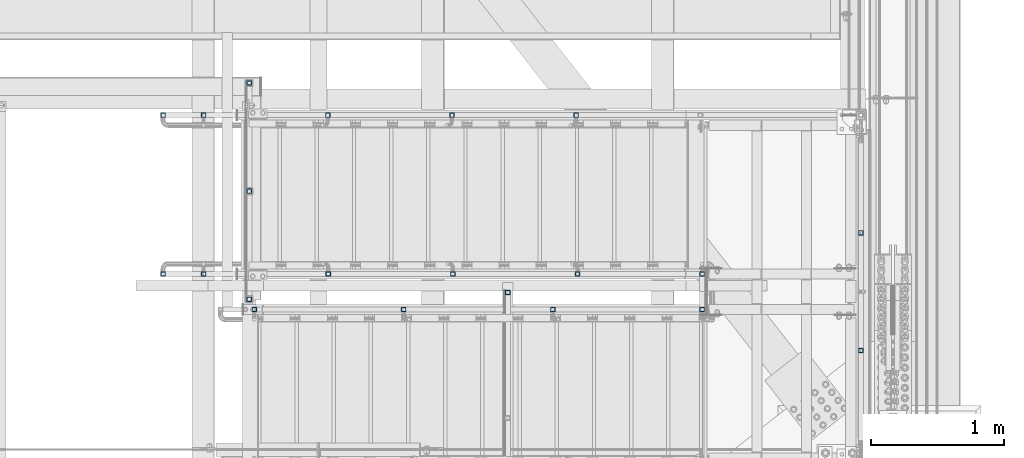
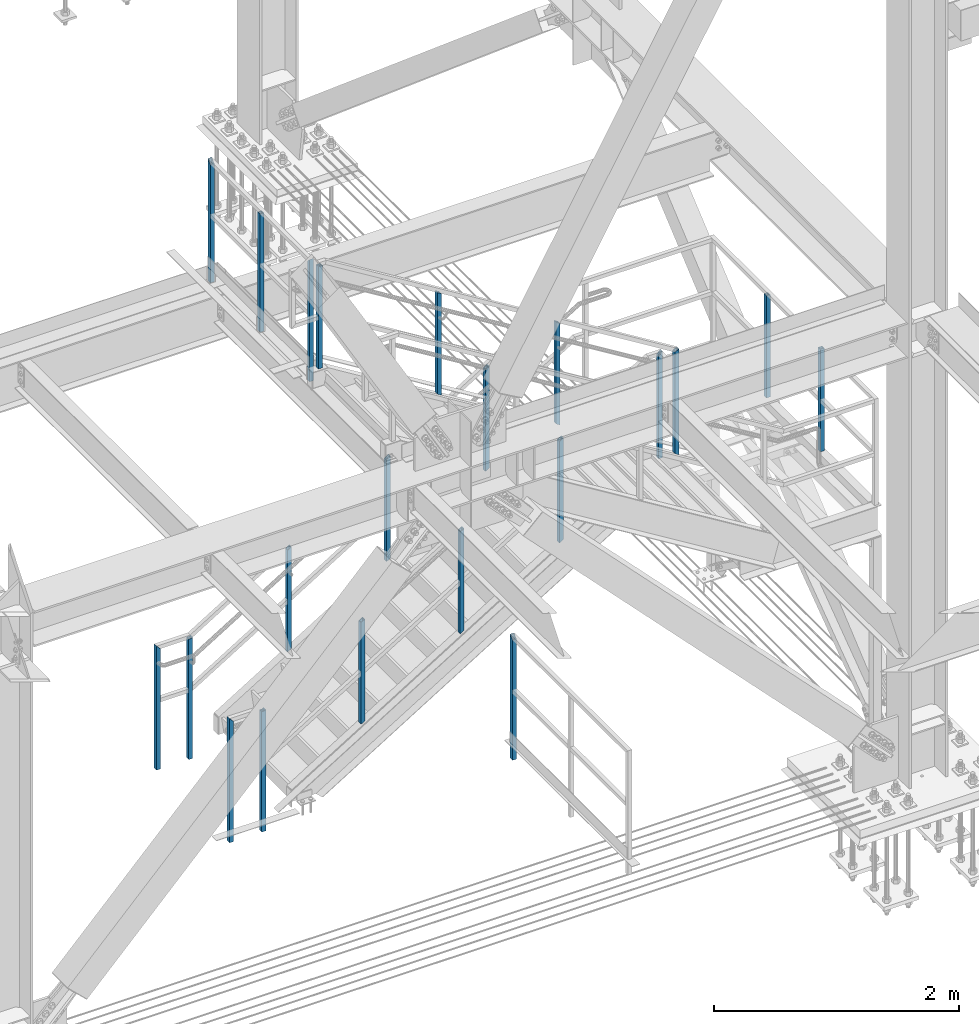
# One storey, part 1411 of 3843: 21 columns, 6 elements without a shape of their own.
"""IFC2X3 building model written with IfcOpenShell, lengths in millimetres."""

from ifc_helpers import new_model, si_unit, frame, origin_with_axes, place, context, subcontext, project, spatial, faceted_brep, material, type_object, element, aggregate, save


model = new_model("IFC2X3")

# Units and contexts
model_context = context("Model", 3, precision=1e-05, world=origin_with_axes())
body_context = subcontext(model_context, "Body", "Model", "MODEL_VIEW")
ifc_project = project(units=[si_unit("LENGTHUNIT", "METRE", prefix="MILLI"), si_unit("AREAUNIT", "SQUARE_METRE"), si_unit("VOLUMEUNIT", "CUBIC_METRE"), si_unit("MASSUNIT", "GRAM", prefix="KILO"), si_unit("TIMEUNIT", "SECOND"), si_unit("PLANEANGLEUNIT", "RADIAN"), si_unit("SOLIDANGLEUNIT", "STERADIAN"), si_unit("THERMODYNAMICTEMPERATUREUNIT", "DEGREE_CELSIUS"), si_unit("LUMINOUSINTENSITYUNIT", "LUMEN")], contexts=[model_context])

# Site, building, storey
site_placement = place(None, origin_with_axes())
site = spatial("IfcSite", under=ifc_project, at=site_placement, CompositionType="ELEMENT")
building_placement = place(site_placement, origin_with_axes())
building = spatial("IfcBuilding", under=site, at=building_placement, Name="Undefined", CompositionType="ELEMENT")
storey_placement = place(building_placement, origin_with_axes())
storey = spatial("IfcBuildingStorey", under=building, at=storey_placement, Name="Undefined", CompositionType="ELEMENT", Elevation=0.0)

# Assembly, column
assembly_1_placement = place(storey_placement, origin_with_axes())
assembly_1 = element("IfcElementAssembly", 1, at=assembly_1_placement, inside=storey, Name="RAIL", AssemblyPlace="NOTDEFINED", PredefinedType="RIGID_FRAME")
ifc_material = material()
column_type = type_object("IfcColumnType", Name="HSS1-1/2X1-1/2X1/4", PredefinedType="NOTDEFINED")
column_1_placement = place(assembly_1_placement, frame((84213.6999999997, 16725.9, 32715.1999999846), z_axis=(-1.0, 0.0, 0.0), x_axis=(0.0, 0.0, 1.0)))
column_1 = element("IfcColumn", 2, at=column_1_placement, type_object=column_type, material=ifc_material, Name="POST", ObjectType="HSS1-1/2X1-1/2X1/4", context=body_context, shape_type="Brep", body=[
    faceted_brep([(1047.75000076629, -19.0499992350015, 19.0499992349942), (1047.75000076629, 19.0499992350015, 19.0499992349942), (25.4000000135893, 19.0499992350015, 19.0499992349942), (25.4000000135893, -19.0499992350015, 19.0499992349942), (1085.84999923629, -19.0499992350015, -19.0499992349942), (25.4000000135893, -19.0499992350015, -19.0499992349942), (1085.84999923629, 19.0499992350015, -19.0499992349942), (25.4000000135893, 19.0499992350015, -19.0499992349942), (1054.10000067129, -12.6999993300014, 12.6999993299978), (1054.10000067129, 12.6999993300014, 12.6999993299978), (1079.49999933128, 12.6999993300014, -12.6999993299978), (1079.49999933128, -12.6999993300014, -12.6999993299978), (25.4000000135893, -12.6999993300014, 12.6999993299978), (25.4000000135893, 12.6999993300014, 12.6999993299978), (25.4000000135893, 12.6999993300014, -12.6999993299978), (25.4000000135893, -12.6999993300014, -12.6999993299978)], [[[0, 1, 2, 3]], [[4, 0, 3, 5]], [[6, 4, 5, 7]], [[1, 6, 7, 2]], [[0, 4, 6, 1], [8, 9, 10, 11]], [[9, 8, 12, 13]], [[10, 9, 13, 14]], [[11, 10, 14, 15]], [[8, 11, 15, 12]], [[7, 5, 3, 2], [14, 13, 12, 15]]]),
])

# Assembly, columns
assembly_2_placement = place(storey_placement, origin_with_axes())
assembly_2 = element("IfcElementAssembly", 3, at=assembly_2_placement, inside=storey, Name="RAIL", AssemblyPlace="NOTDEFINED", PredefinedType="RIGID_FRAME")
column_2_placement = place(assembly_2_placement, frame((80810.1, 17348.2, 34950.4), z_axis=(-1.0, 0.0, 0.0), x_axis=(0.0, 0.0, 1.0)))
column_2 = element("IfcColumn", 4, at=column_2_placement, type_object=column_type, material=ifc_material, Name="POST", ObjectType="HSS1-1/2X1-1/2X1/4", context=body_context, shape_type="Brep", body=[
    faceted_brep([(-133.350000731458, 12.6999993300014, -12.6999993299978), (-133.350000731458, -12.6999993300014, -12.6999993299978), (1047.75000076497, -12.6999993300014, -12.6999993299978), (1047.75000076497, 12.6999993300014, -12.6999993299978), (-133.350000731458, -12.6999993300014, 12.6999993299978), (1047.75000076497, -12.6999993300014, 12.6999993299978), (-133.350000731458, 12.6999993300014, 12.6999993299978), (1047.75000076497, 12.6999993300014, 12.6999993299978), (-133.350000731458, 19.0499992350015, -19.0499992350015), (-133.350000731458, 19.0499992350015, 19.0499992350015), (1047.75000076629, 19.0499992350015, 19.0499992349942), (1047.750000765, 19.0499992350015, -19.0499992350015), (-133.350000731458, -19.0499992350015, 19.0499992350015), (1047.75000076629, -19.0499992350015, 19.0499992349942), (-133.350000731458, -19.0499992350015, -19.0499992350015), (1047.750000765, -19.0499992350015, -19.0499992350015)], [[[0, 1, 2, 3]], [[1, 4, 5, 2]], [[4, 6, 7, 5]], [[6, 0, 3, 7]], [[8, 9, 10, 11]], [[9, 12, 13, 10]], [[12, 14, 15, 13]], [[14, 8, 11, 15]], [[13, 15, 11, 10], [5, 7, 3, 2]], [[14, 12, 9, 8], [6, 4, 1, 0]]]),
])
column_3_placement = place(assembly_2_placement, frame((80810.1, 16535.4, 34950.4), z_axis=(-1.0, 0.0, 0.0), x_axis=(0.0, 0.0, 1.0)))
column_3 = element("IfcColumn", 5, at=column_3_placement, type_object=column_type, material=ifc_material, Name="POST", ObjectType="HSS1-1/2X1-1/2X1/4", context=body_context, shape_type="Brep", body=[
    faceted_brep([(-133.350000731458, 12.6999993300014, -12.6999993299978), (-133.350000731458, -12.6999993300014, -12.6999993299978), (1079.49999933128, -12.6999993300014, -12.6999993299978), (1054.10000067001, 12.6999993300014, -12.6999993299978), (-133.350000731458, -12.6999993300014, 12.6999993299978), (1079.49999933, -12.6999993300014, 12.6999993299978), (-133.350000731458, 12.6999993300014, 12.6999993299978), (1054.10000067129, 12.6999993300014, 12.6999993299978), (-133.350000731458, 19.0499992350015, -19.0499992350015), (-133.350000731458, 19.0499992350015, 19.0499992350015), (1047.75000076629, 19.0499992350015, 19.0499992349942), (1047.750000765, 19.0499992350015, -19.0499992350015), (-133.350000731458, -19.0499992350015, 19.0499992350015), (1085.849999235, -19.0499992350015, 19.0499992350015), (-133.350000731458, -19.0499992350015, -19.0499992350015), (1085.84999923629, -19.0499992350015, -19.0499992349942)], [[[0, 1, 2, 3]], [[1, 4, 5, 2]], [[4, 6, 7, 5]], [[6, 0, 3, 7]], [[8, 9, 10, 11]], [[9, 12, 13, 10]], [[12, 14, 15, 13]], [[14, 8, 11, 15]], [[13, 15, 11, 10], [5, 7, 3, 2]], [[14, 12, 9, 8], [6, 4, 1, 0]]]),
])
column_4_placement = place(assembly_2_placement, frame((80810.1, 18161.0, 34950.4), z_axis=(-1.0, 0.0, 0.0), x_axis=(0.0, 0.0, 1.0)))
column_4 = element("IfcColumn", 6, at=column_4_placement, type_object=column_type, material=ifc_material, Name="POST", ObjectType="HSS1-1/2X1-1/2X1/4", context=body_context, shape_type="Brep", body=[
    faceted_brep([(-133.350000731458, 12.6999993300014, -12.6999993299978), (-133.350000731458, -12.6999993300014, -12.6999993299978), (1054.10000067001, -12.6999993300014, -12.6999993299978), (1079.49999933128, 12.6999993300014, -12.6999993299978), (-133.350000731458, -12.6999993300014, 12.6999993299978), (1054.10000067129, -12.6999993300014, 12.6999993299978), (-133.350000731458, 12.6999993300014, 12.6999993299978), (1079.49999933, 12.6999993300014, 12.6999993299978), (-133.350000731458, 19.0499992350015, -19.0499992350015), (-133.350000731458, 19.0499992350015, 19.0499992350015), (1085.849999235, 19.0499992350015, 19.0499992350015), (1085.84999923629, 19.0499992350015, -19.0499992349942), (-133.350000731458, -19.0499992350015, 19.0499992350015), (1047.75000076629, -19.0499992350015, 19.0499992349942), (-133.350000731458, -19.0499992350015, -19.0499992350015), (1047.750000765, -19.0499992350015, -19.0499992350015)], [[[0, 1, 2, 3]], [[1, 4, 5, 2]], [[4, 6, 7, 5]], [[6, 0, 3, 7]], [[8, 9, 10, 11]], [[9, 12, 13, 10]], [[12, 14, 15, 13]], [[14, 8, 11, 15]], [[13, 15, 11, 10], [5, 7, 3, 2]], [[14, 12, 9, 8], [6, 4, 1, 0]]]),
])
aggregate(assembly_2, [column_2, column_3, column_4])

# Assembly, column
assembly_3_placement = place(storey_placement, origin_with_axes())
assembly_3 = element("IfcElementAssembly", 7, at=assembly_3_placement, inside=storey, Name="RAIL", AssemblyPlace="NOTDEFINED", PredefinedType="RIGID_FRAME")
column_5_placement = place(assembly_3_placement, frame((82753.1999999997, 16586.2, 30480.0), z_axis=(-1.0, 0.0, 0.0), x_axis=(0.0, 0.0, 1.0)))
column_5 = element("IfcColumn", 8, at=column_5_placement, type_object=column_type, material=ifc_material, Name="POST", ObjectType="HSS1-1/2X1-1/2X1/4", context=body_context, shape_type="Brep", body=[
    faceted_brep([(-152.399999977541, 12.6999993299978, -12.6999993299978), (-152.399999977541, -12.6999993299978, -12.6999993299978), (1054.10000067001, -12.6999993300014, -12.6999993299978), (1079.49999933128, 12.6999993300014, -12.6999993299978), (-152.399999977541, -12.6999993299978, 12.6999993299978), (1054.10000067129, -12.6999993300014, 12.6999993299978), (-152.399999977541, 12.6999993299978, 12.6999993299978), (1079.49999933, 12.6999993300014, 12.6999993299978), (-152.399999977541, 19.0499992350015, -19.0499992349942), (-152.399999977541, 19.0499992350015, 19.0499992349942), (1085.849999235, 19.0499992350015, 19.0499992350015), (1085.84999923629, 19.0499992350015, -19.0499992349942), (-152.399999977541, -19.0499992350015, 19.0499992349942), (1047.75000076629, -19.0499992350015, 19.0499992349942), (-152.399999977541, -19.0499992350015, -19.0499992349942), (1047.750000765, -19.0499992350015, -19.0499992350015)], [[[0, 1, 2, 3]], [[1, 4, 5, 2]], [[4, 6, 7, 5]], [[6, 0, 3, 7]], [[8, 9, 10, 11]], [[9, 12, 13, 10]], [[12, 14, 15, 13]], [[14, 8, 11, 15]], [[13, 15, 11, 10], [5, 7, 3, 2]], [[14, 12, 9, 8], [6, 4, 1, 0]]]),
])
aggregate(assembly_3, [column_5])

assembly_4_placement = place(storey_placement, origin_with_axes())
assembly_4 = element("IfcElementAssembly", 9, at=assembly_4_placement, inside=storey, Name="RAIL", AssemblyPlace="NOTDEFINED", PredefinedType="RIGID_FRAME")
column_6_placement = place(assembly_4_placement, frame((80848.2000000002, 16459.2, 34950.4), z_axis=(1.0, 0.0, 0.0), x_axis=(0.0, 0.0, 1.0)))
column_6 = element("IfcColumn", 10, at=column_6_placement, type_object=column_type, material=ifc_material, Name="POST", ObjectType="HSS1-1/2X1-1/2X1/4", context=body_context, shape_type="Brep", body=[
    faceted_brep([(1047.75000076629, -19.0499992350015, 19.0499992349942), (1047.75000076629, 19.0499992350015, 19.0499992349942), (25.4000000135893, 19.0499992350015, 19.0499992349942), (25.4000000135893, -19.0499992350015, 19.0499992349942), (1047.750000765, -19.0499992350015, -19.0499992350015), (25.4000000135893, -19.0499992350015, -19.0499992349942), (1047.750000765, 19.0499992350015, -19.0499992350015), (25.4000000135893, 19.0499992350015, -19.0499992349942), (1047.75000076497, -12.6999993300014, 12.6999993299978), (1047.75000076497, 12.6999993300014, 12.6999993299978), (1047.75000076497, 12.6999993300014, -12.6999993299978), (1047.75000076497, -12.6999993300014, -12.6999993299978), (25.4000000135893, -12.6999993300014, 12.6999993299978), (25.4000000135893, 12.6999993300014, 12.6999993299978), (25.4000000135893, 12.6999993300014, -12.6999993299978), (25.4000000135893, -12.6999993300014, -12.6999993299978)], [[[0, 1, 2, 3]], [[4, 0, 3, 5]], [[6, 4, 5, 7]], [[1, 6, 7, 2]], [[0, 4, 6, 1], [8, 9, 10, 11]], [[9, 8, 12, 13]], [[10, 9, 13, 14]], [[11, 10, 14, 15]], [[8, 11, 15, 12]], [[7, 5, 3, 2], [14, 13, 12, 15]]]),
])

# Assembly, columns
assembly_5_placement = place(storey_placement, origin_with_axes())
assembly_5 = element("IfcElementAssembly", 11, at=assembly_5_placement, inside=storey, Name="RAIL", AssemblyPlace="NOTDEFINED", PredefinedType="RIGID_FRAME")
column_7_placement = place(assembly_5_placement, frame((83267.5499999997, 17919.7, 32233.1164747212), z_axis=(-1.0, 0.0, 0.0), x_axis=(0.0, 0.0, 1.0)))
column_7 = element("IfcColumn", 12, at=column_7_placement, type_object=column_type, material=ifc_material, Name="POST", ObjectType="HSS1-1/2X1-1/2X1/4", context=body_context, shape_type="Brep", body=[
    faceted_brep([(7.81538423420716, 12.6999993299978, -12.6999993300014), (7.81538423420716, -12.6999993299978, -12.6999993300014), (1022.42309164321, -12.6999993299978, -12.6999993300014), (1022.42309164321, 12.6999993299978, -12.6999993300014), (-7.81538414671377, -12.6999993299978, 12.6999993300014), (1006.79232326229, -12.6999993299978, 12.6999993300014), (-7.81538414671377, 12.6999993299978, 12.6999993300014), (1006.79232326229, 12.6999993299978, 12.6999993300014), (11.7230764771302, 19.0499992350015, -19.0499992350015), (-11.7230763896368, 19.0499992350015, 19.0499992350015), (1002.88463101937, 19.0499992350015, 19.0499992350015), (1026.33078388613, 19.0499992350015, -19.0499992350015), (-11.7230763896368, -19.0499992350015, 19.0499992350015), (1002.88463101937, -19.0499992350015, 19.0499992350015), (11.7230764771302, -19.0499992350015, -19.0499992350015), (1026.33078388613, -19.0499992350015, -19.0499992350015)], [[[0, 1, 2, 3]], [[1, 4, 5, 2]], [[4, 6, 7, 5]], [[6, 0, 3, 7]], [[8, 9, 10, 11]], [[9, 12, 13, 10]], [[12, 14, 15, 13]], [[14, 8, 11, 15]], [[13, 15, 11, 10], [5, 7, 3, 2]], [[14, 12, 9, 8], [6, 4, 1, 0]]]),
])
column_8_placement = place(assembly_5_placement, frame((82334.0999999997, 17919.7, 31658.6857053218), z_axis=(-1.0, 0.0, 0.0), x_axis=(0.0, 0.0, 1.0)))
column_8 = element("IfcColumn", 13, at=column_8_placement, type_object=column_type, material=ifc_material, Name="POST", ObjectType="HSS1-1/2X1-1/2X1/4", context=body_context, shape_type="Brep", body=[
    faceted_brep([(7.81538423420716, 12.6999993299978, -12.6999993300014), (7.81538423420716, -12.6999993299978, -12.6999993300014), (1022.42309164321, -12.6999993299978, -12.6999993300014), (1022.42309164321, 12.6999993299978, -12.6999993300014), (-7.81538414671377, -12.6999993299978, 12.6999993300014), (1006.79232326229, -12.6999993299978, 12.6999993300014), (-7.81538414671377, 12.6999993299978, 12.6999993300014), (1006.79232326229, 12.6999993299978, 12.6999993300014), (11.7230764771302, 19.0499992350015, -19.0499992350015), (-11.7230763896368, 19.0499992350015, 19.0499992350015), (1002.88463101937, 19.0499992350015, 19.0499992350015), (1026.33078388613, 19.0499992350015, -19.0499992350015), (-11.7230763896368, -19.0499992350015, 19.0499992350015), (1002.88463101937, -19.0499992350015, 19.0499992350015), (11.7230764771302, -19.0499992350015, -19.0499992350015), (1026.33078388613, -19.0499992350015, -19.0499992350015)], [[[0, 1, 2, 3]], [[1, 4, 5, 2]], [[4, 6, 7, 5]], [[6, 0, 3, 7]], [[8, 9, 10, 11]], [[9, 12, 13, 10]], [[12, 14, 15, 13]], [[14, 8, 11, 15]], [[13, 15, 11, 10], [5, 7, 3, 2]], [[14, 12, 9, 8], [6, 4, 1, 0]]]),
])
column_9_placement = place(assembly_5_placement, frame((81400.6499999997, 17919.7, 31084.2549359224), z_axis=(-1.0, 0.0, 0.0), x_axis=(0.0, 0.0, 1.0)))
column_9 = element("IfcColumn", 14, at=column_9_placement, type_object=column_type, material=ifc_material, Name="POST", ObjectType="HSS1-1/2X1-1/2X1/4", context=body_context, shape_type="Brep", body=[
    faceted_brep([(7.81538423420716, 12.6999993299978, -12.6999993300014), (7.81538423420716, -12.6999993299978, -12.6999993300014), (1022.42309164321, -12.6999993299978, -12.6999993300014), (1022.42309164321, 12.6999993299978, -12.6999993300014), (-7.81538414671377, -12.6999993299978, 12.6999993300014), (1006.79232326229, -12.6999993299978, 12.6999993300014), (-7.81538414671377, 12.6999993299978, 12.6999993300014), (1006.79232326229, 12.6999993299978, 12.6999993300014), (11.7230764771302, 19.0499992350015, -19.0499992350015), (-11.7230763896368, 19.0499992350015, 19.0499992350015), (1002.88463101937, 19.0499992350015, 19.0499992350015), (1026.33078388613, 19.0499992350015, -19.0499992350015), (-11.7230763896368, -19.0499992350015, 19.0499992350015), (1002.88463101937, -19.0499992350015, 19.0499992350015), (11.7230764771302, -19.0499992350015, -19.0499992350015), (1026.33078388613, -19.0499992350015, -19.0499992350015)], [[[0, 1, 2, 3]], [[1, 4, 5, 2]], [[4, 6, 7, 5]], [[6, 0, 3, 7]], [[8, 9, 10, 11]], [[9, 12, 13, 10]], [[12, 14, 15, 13]], [[14, 8, 11, 15]], [[13, 15, 11, 10], [5, 7, 3, 2]], [[14, 12, 9, 8], [6, 4, 1, 0]]]),
])
column_10_placement = place(assembly_5_placement, frame((80467.1999999997, 17919.7, 30480.0), z_axis=(-1.0, 0.0, 0.0), x_axis=(0.0, 0.0, 1.0)))
column_10 = element("IfcColumn", 15, at=column_10_placement, type_object=column_type, material=ifc_material, Name="POST", ObjectType="HSS1-1/2X1-1/2X1/4", context=body_context, shape_type="Brep", body=[
    faceted_brep([(1047.75000076629, -19.0499992350015, 19.0499992349942), (1047.75000076818, -19.0499992350015, -5.39195351277885), (1047.75000076818, -12.6999993300014, -5.39195351277885), (1047.75000076497, -12.6999993300014, 12.6999993299978), (1047.75000076497, 12.6999993300014, 12.6999993299978), (1047.75000076819, 12.6999993300014, -5.39195351277885), (1047.75000076819, 19.0499992349978, -5.39195351277885), (1047.75000076629, 19.0499992350015, 19.0499992349942), (1056.15495197957, -19.0499992350051, -19.0499992350015), (1056.15495197957, 19.0499992350015, -19.0499992350015), (1052.2472597314, 12.6999993300014, -12.6999993299978), (1052.2472597314, -12.6999993300014, -12.6999993299978), (-152.399999977541, 19.0499992350015, 19.0499992349942), (-152.399999977541, -19.0499992350015, 19.0499992349942), (-152.399999977541, -19.0499992350015, -19.0499992349942), (-152.399999977541, 19.0499992350015, -19.0499992349942), (-152.399999977541, 12.6999993299978, 12.6999993299978), (-152.399999977541, -12.6999993299978, 12.6999993299978), (-152.399999977541, -12.6999993299978, -12.6999993299978), (-152.399999977541, 12.6999993299978, -12.6999993299978)], [[[0, 1, 2, 3, 4, 5, 6, 7]], [[8, 9, 6, 5, 10, 11, 2, 1]], [[12, 13, 0, 7]], [[0, 13, 14, 8, 1]], [[14, 15, 9, 8]], [[15, 12, 7, 6, 9]], [[14, 13, 12, 15], [16, 17, 18, 19]], [[19, 18, 11, 10]], [[4, 16, 19, 10, 5]], [[17, 16, 4, 3]], [[18, 17, 3, 2, 11]]]),
])
column_11_placement = place(assembly_5_placement, frame((80162.3999999997, 17919.7, 30480.0), z_axis=(-1.0, 0.0, 0.0), x_axis=(0.0, 0.0, 1.0)))
column_11 = element("IfcColumn", 16, at=column_11_placement, type_object=column_type, material=ifc_material, Name="POST", ObjectType="HSS1-1/2X1-1/2X1/4", context=body_context, shape_type="Brep", body=[
    faceted_brep([(-152.399999977541, 12.6999993299978, -12.6999993299978), (-152.399999977541, -12.6999993299978, -12.6999993299978), (1054.10000067001, -12.6999993300014, -12.6999993299978), (1054.10000067001, 12.6999993300014, -12.6999993299978), (-152.399999977541, -12.6999993299978, 12.6999993299978), (1079.49999933, -12.6999993300014, 12.6999993299978), (-152.399999977541, 12.6999993299978, 12.6999993299978), (1079.49999933, 12.6999993300014, 12.6999993299978), (-152.399999977541, 19.0499992350015, -19.0499992349942), (-152.399999977541, 19.0499992350015, 19.0499992349942), (1085.849999235, 19.0499992350015, 19.0499992350015), (1047.750000765, 19.0499992350015, -19.0499992350015), (-152.399999977541, -19.0499992350015, 19.0499992349942), (1085.849999235, -19.0499992350015, 19.0499992350015), (-152.399999977541, -19.0499992350015, -19.0499992349942), (1047.750000765, -19.0499992350015, -19.0499992350015)], [[[0, 1, 2, 3]], [[1, 4, 5, 2]], [[4, 6, 7, 5]], [[6, 0, 3, 7]], [[8, 9, 10, 11]], [[9, 12, 13, 10]], [[12, 14, 15, 13]], [[14, 8, 11, 15]], [[13, 15, 11, 10], [5, 7, 3, 2]], [[14, 12, 9, 8], [6, 4, 1, 0]]]),
])
aggregate(assembly_5, [column_7, column_8, column_9, column_10, column_11])

assembly_6_placement = place(storey_placement, origin_with_axes())
assembly_6 = element("IfcElementAssembly", 17, at=assembly_6_placement, inside=storey, Name="RAIL", AssemblyPlace="NOTDEFINED", PredefinedType="RIGID_FRAME")
column_12_placement = place(assembly_6_placement, frame((85407.4999999661, 17034.9333333333, 32740.5999999989), z_axis=(-1.0, 0.0, 0.0), x_axis=(0.0, 0.0, 1.0)))
column_12 = element("IfcColumn", 18, at=column_12_placement, type_object=column_type, material=ifc_material, Name="POST", ObjectType="HSS1-1/2X1-1/2X1/4", context=body_context, shape_type="Brep", body=[
    faceted_brep([(0.0, 12.6999993299978, -12.6999993300014), (0.0, -12.6999993299978, -12.6999993300014), (1022.35000076501, -12.6999993299978, -12.6999993300014), (1022.35000076501, 12.6999993299978, -12.6999993300014), (0.0, -12.6999993299978, 12.6999993300014), (1022.35000076501, -12.6999993299978, 12.6999993300014), (0.0, 12.6999993299978, 12.6999993300014), (1022.35000076501, 12.6999993299978, 12.6999993300014), (0.0, 19.0500000000029, -19.0499999999993), (0.0, 19.0499992350015, 19.0499992350015), (1022.35000076501, 19.0499992350015, 19.0499992350015), (1022.35000076501, 19.0499992350015, -19.0499992350015), (0.0, -19.0499992350015, 19.0499992350015), (1022.35000076501, -19.0499992350015, 19.0499992350015), (0.0, -19.0499992350015, -19.0499992350015), (1022.35000076501, -19.0499992350015, -19.0499992350015)], [[[0, 1, 2, 3]], [[1, 4, 5, 2]], [[4, 6, 7, 5]], [[6, 0, 3, 7]], [[8, 9, 10, 11]], [[9, 12, 13, 10]], [[12, 14, 15, 13]], [[14, 8, 11, 15]], [[13, 15, 11, 10], [5, 7, 3, 2]], [[14, 12, 9, 8], [6, 4, 1, 0]]]),
])
column_13_placement = place(assembly_6_placement, frame((85407.4999999661, 16150.1666666667, 32740.5999999989), z_axis=(-1.0, 0.0, 0.0), x_axis=(0.0, 0.0, 1.0)))
column_13 = element("IfcColumn", 19, at=column_13_placement, type_object=column_type, material=ifc_material, Name="POST", ObjectType="HSS1-1/2X1-1/2X1/4", context=body_context, shape_type="Brep", body=[
    faceted_brep([(0.0, 12.6999993299978, -12.6999993300014), (0.0, -12.6999993299978, -12.6999993300014), (1022.35000076501, -12.6999993299978, -12.6999993300014), (1022.35000076501, 12.6999993299978, -12.6999993300014), (0.0, -12.6999993299978, 12.6999993300014), (1022.35000076501, -12.6999993299978, 12.6999993300014), (0.0, 12.6999993299978, 12.6999993300014), (1022.35000076501, 12.6999993299978, 12.6999993300014), (0.0, 19.0500000000029, -19.0499999999993), (0.0, 19.0499992350015, 19.0499992350015), (1022.35000076501, 19.0499992350015, 19.0499992350015), (1022.35000076501, 19.0499992350015, -19.0499992350015), (0.0, -19.0499992350015, 19.0499992350015), (1022.35000076501, -19.0499992350015, 19.0499992350015), (0.0, -19.0499992350015, -19.0499992350015), (1022.35000076501, -19.0499992350015, -19.0499992350015)], [[[0, 1, 2, 3]], [[1, 4, 5, 2]], [[4, 6, 7, 5]], [[6, 0, 3, 7]], [[8, 9, 10, 11]], [[9, 12, 13, 10]], [[12, 14, 15, 13]], [[14, 8, 11, 15]], [[13, 15, 11, 10], [5, 7, 3, 2]], [[14, 12, 9, 8], [6, 4, 1, 0]]]),
])
aggregate(assembly_6, [column_12, column_13])

# Column
column_14_placement = place(assembly_4_placement, frame((81970.0333333243, 16459.2, 34321.1267310448), z_axis=(1.0, 0.0, 0.0), x_axis=(0.0, 0.0, 1.0)))
column_14 = element("IfcColumn", 20, at=column_14_placement, type_object=column_type, material=ifc_material, Name="POST", ObjectType="HSS1-1/2X1-1/2X1/4", context=body_context, shape_type="Brep", body=[
    faceted_brep([(7.81538423420716, 12.6999993299978, -12.6999993300014), (7.81538423420716, -12.6999993299978, -12.6999993300014), (1022.42309164321, -12.6999993299978, -12.6999993300014), (1022.42309164321, 12.6999993299978, -12.6999993300014), (-7.81538414671377, -12.6999993299978, 12.6999993300014), (1006.79232326229, -12.6999993299978, 12.6999993300014), (-7.81538414671377, 12.6999993299978, 12.6999993300014), (1006.79232326229, 12.6999993299978, 12.6999993300014), (11.7230764771302, 19.0499992350015, -19.0499992350015), (-11.7230763896368, 19.0499992350015, 19.0499992350015), (1002.88463101937, 19.0499992350015, 19.0499992350015), (1026.33078388613, 19.0499992350015, -19.0499992350015), (-11.7230763896368, -19.0499992350015, 19.0499992350015), (1002.88463101937, -19.0499992350015, 19.0499992350015), (11.7230764771302, -19.0499992350015, -19.0499992350015), (1026.33078388613, -19.0499992350015, -19.0499992350015)], [[[0, 1, 2, 3]], [[1, 4, 5, 2]], [[4, 6, 7, 5]], [[6, 0, 3, 7]], [[8, 9, 10, 11]], [[9, 12, 13, 10]], [[12, 14, 15, 13]], [[14, 8, 11, 15]], [[13, 15, 11, 10], [5, 7, 3, 2]], [[14, 12, 9, 8], [6, 4, 1, 0]]]),
])

column_15_placement = place(assembly_4_placement, frame((83091.8666666484, 16459.2, 33630.7677564889), z_axis=(1.0, 0.0, 0.0), x_axis=(0.0, 0.0, 1.0)))
column_15 = element("IfcColumn", 21, at=column_15_placement, type_object=column_type, material=ifc_material, Name="POST", ObjectType="HSS1-1/2X1-1/2X1/4", context=body_context, shape_type="Brep", body=[
    faceted_brep([(7.81538423420716, 12.6999993299978, -12.6999993300014), (7.81538423420716, -12.6999993299978, -12.6999993300014), (1022.42309164321, -12.6999993299978, -12.6999993300014), (1022.42309164321, 12.6999993299978, -12.6999993300014), (-7.81538414671377, -12.6999993299978, 12.6999993300014), (1006.79232326229, -12.6999993299978, 12.6999993300014), (-7.81538414671377, 12.6999993299978, 12.6999993300014), (1006.79232326229, 12.6999993299978, 12.6999993300014), (11.7230764771302, 19.0499992350015, -19.0499992350015), (-11.7230763896368, 19.0499992350015, 19.0499992350015), (1002.88463101937, 19.0499992350015, 19.0499992350015), (1026.33078388613, 19.0499992350015, -19.0499992350015), (-11.7230763896368, -19.0499992350015, 19.0499992350015), (1002.88463101937, -19.0499992350015, 19.0499992350015), (11.7230764771302, -19.0499992350015, -19.0499992350015), (1026.33078388613, -19.0499992350015, -19.0499992350015)], [[[0, 1, 2, 3]], [[1, 4, 5, 2]], [[4, 6, 7, 5]], [[6, 0, 3, 7]], [[8, 9, 10, 11]], [[9, 12, 13, 10]], [[12, 14, 15, 13]], [[14, 8, 11, 15]], [[13, 15, 11, 10], [5, 7, 3, 2]], [[14, 12, 9, 8], [6, 4, 1, 0]]]),
])

column_16_placement = place(assembly_4_placement, frame((84213.6999999724, 16459.2, 32940.408781933), z_axis=(1.0, 0.0, 0.0), x_axis=(0.0, 0.0, 1.0)))
column_16 = element("IfcColumn", 22, at=column_16_placement, type_object=column_type, material=ifc_material, Name="POST", ObjectType="HSS1-1/2X1-1/2X1/4", context=body_context, shape_type="Brep", body=[
    faceted_brep([(7.81538423420716, 12.6999993299978, -12.6999993300014), (7.81538423420716, -12.6999993299978, -12.6999993300014), (1029.87913425495, -12.6999993299978, -12.6999993300014), (1029.87913425495, 12.6999993299978, -12.6999993300014), (-7.81538414671377, -12.6999993299978, 12.6999993300014), (1044.07253145806, -12.6999993299978, 12.6999993300014), (-7.81538414671377, 12.6999993299978, 12.6999993300014), (1044.07253145806, 12.6999993299978, 12.6999993300014), (11.7230764771302, 19.0499992350015, -19.0499992350015), (-11.7230763896368, 19.0499992350015, 19.0499992350015), (1047.62088089295, 19.0499992350015, 19.0499992350015), (1026.33078388613, 19.0499992350015, -19.0499992350015), (-11.7230763896368, -19.0499992350015, 19.0499992350015), (1047.62088089295, -19.0499992350015, 19.0499992350015), (11.7230764771302, -19.0499992350015, -19.0499992350015), (1026.33078388613, -19.0499992350015, -19.0499992350015)], [[[0, 1, 2, 3]], [[1, 4, 5, 2]], [[4, 6, 7, 5]], [[6, 0, 3, 7]], [[8, 9, 10, 11]], [[9, 12, 13, 10]], [[12, 14, 15, 13]], [[14, 8, 11, 15]], [[13, 15, 11, 10], [5, 7, 3, 2]], [[14, 12, 9, 8], [6, 4, 1, 0]]]),
])

aggregate(assembly_4, [column_6, column_14, column_15, column_16])

column_17_placement = place(assembly_1_placement, frame((83277.0749999997, 16725.9, 32238.9780131844), z_axis=(-1.0, 0.0, 0.0), x_axis=(0.0, 0.0, 1.0)))
column_17 = element("IfcColumn", 23, at=column_17_placement, type_object=column_type, material=ifc_material, Name="POST", ObjectType="HSS1-1/2X1-1/2X1/4", context=body_context, shape_type="Brep", body=[
    faceted_brep([(7.81538423420716, 12.6999993299978, -12.6999993300014), (7.81538423420716, -12.6999993299978, -12.6999993300014), (1022.42309164321, -12.6999993299978, -12.6999993300014), (1022.42309164321, 12.6999993299978, -12.6999993300014), (-7.81538414671377, -12.6999993299978, 12.6999993300014), (1006.79232326229, -12.6999993299978, 12.6999993300014), (-7.81538414671377, 12.6999993299978, 12.6999993300014), (1006.79232326229, 12.6999993299978, 12.6999993300014), (11.7230764771302, 19.0499992350015, -19.0499992350015), (-11.7230763896368, 19.0499992350015, 19.0499992350015), (1002.88463101937, 19.0499992350015, 19.0499992350015), (1026.33078388613, 19.0499992350015, -19.0499992350015), (-11.7230763896368, -19.0499992350015, 19.0499992350015), (1002.88463101937, -19.0499992350015, 19.0499992350015), (11.7230764771302, -19.0499992350015, -19.0499992350015), (1026.33078388613, -19.0499992350015, -19.0499992350015)], [[[0, 1, 2, 3]], [[1, 4, 5, 2]], [[4, 6, 7, 5]], [[6, 0, 3, 7]], [[8, 9, 10, 11]], [[9, 12, 13, 10]], [[12, 14, 15, 13]], [[14, 8, 11, 15]], [[13, 15, 11, 10], [5, 7, 3, 2]], [[14, 12, 9, 8], [6, 4, 1, 0]]]),
])

column_18_placement = place(assembly_1_placement, frame((82340.4499999997, 16725.9, 31662.5933976306), z_axis=(-1.0, 0.0, 0.0), x_axis=(0.0, 0.0, 1.0)))
column_18 = element("IfcColumn", 24, at=column_18_placement, type_object=column_type, material=ifc_material, Name="POST", ObjectType="HSS1-1/2X1-1/2X1/4", context=body_context, shape_type="Brep", body=[
    faceted_brep([(7.81538423420716, 12.6999993299978, -12.6999993300014), (7.81538423420716, -12.6999993299978, -12.6999993300014), (1022.42309164321, -12.6999993299978, -12.6999993300014), (1022.42309164321, 12.6999993299978, -12.6999993300014), (-7.81538414671377, -12.6999993299978, 12.6999993300014), (1006.79232326229, -12.6999993299978, 12.6999993300014), (-7.81538414671377, 12.6999993299978, 12.6999993300014), (1006.79232326229, 12.6999993299978, 12.6999993300014), (11.7230764771302, 19.0499992350015, -19.0499992350015), (-11.7230763896368, 19.0499992350015, 19.0499992350015), (1002.88463101937, 19.0499992350015, 19.0499992350015), (1026.33078388613, 19.0499992350015, -19.0499992350015), (-11.7230763896368, -19.0499992350015, 19.0499992350015), (1002.88463101937, -19.0499992350015, 19.0499992350015), (11.7230764771302, -19.0499992350015, -19.0499992350015), (1026.33078388613, -19.0499992350015, -19.0499992350015)], [[[0, 1, 2, 3]], [[1, 4, 5, 2]], [[4, 6, 7, 5]], [[6, 0, 3, 7]], [[8, 9, 10, 11]], [[9, 12, 13, 10]], [[12, 14, 15, 13]], [[14, 8, 11, 15]], [[13, 15, 11, 10], [5, 7, 3, 2]], [[14, 12, 9, 8], [6, 4, 1, 0]]]),
])

column_19_placement = place(assembly_1_placement, frame((81403.8249999997, 16725.9, 31086.2087820768), z_axis=(-1.0, 0.0, 0.0), x_axis=(0.0, 0.0, 1.0)))
column_19 = element("IfcColumn", 25, at=column_19_placement, type_object=column_type, material=ifc_material, Name="POST", ObjectType="HSS1-1/2X1-1/2X1/4", context=body_context, shape_type="Brep", body=[
    faceted_brep([(7.81538423420716, 12.6999993299978, -12.6999993300014), (7.81538423420716, -12.6999993299978, -12.6999993300014), (1022.42309164321, -12.6999993299978, -12.6999993300014), (1022.42309164321, 12.6999993299978, -12.6999993300014), (-7.81538414671377, -12.6999993299978, 12.6999993300014), (1006.79232326229, -12.6999993299978, 12.6999993300014), (-7.81538414671377, 12.6999993299978, 12.6999993300014), (1006.79232326229, 12.6999993299978, 12.6999993300014), (11.7230764771302, 19.0499992350015, -19.0499992350015), (-11.7230763896368, 19.0499992350015, 19.0499992350015), (1002.88463101937, 19.0499992350015, 19.0499992350015), (1026.33078388613, 19.0499992350015, -19.0499992350015), (-11.7230763896368, -19.0499992350015, 19.0499992350015), (1002.88463101937, -19.0499992350015, 19.0499992350015), (11.7230764771302, -19.0499992350015, -19.0499992350015), (1026.33078388613, -19.0499992350015, -19.0499992350015)], [[[0, 1, 2, 3]], [[1, 4, 5, 2]], [[4, 6, 7, 5]], [[6, 0, 3, 7]], [[8, 9, 10, 11]], [[9, 12, 13, 10]], [[12, 14, 15, 13]], [[14, 8, 11, 15]], [[13, 15, 11, 10], [5, 7, 3, 2]], [[14, 12, 9, 8], [6, 4, 1, 0]]]),
])

column_20_placement = place(assembly_1_placement, frame((80467.1999999997, 16725.9, 30480.0), z_axis=(-1.0, 0.0, 0.0), x_axis=(0.0, 0.0, 1.0)))
column_20 = element("IfcColumn", 26, at=column_20_placement, type_object=column_type, material=ifc_material, Name="POST", ObjectType="HSS1-1/2X1-1/2X1/4", context=body_context, shape_type="Brep", body=[
    faceted_brep([(1047.75000076629, -19.0499992350015, 19.0499992349942), (1047.75000076818, -19.0499992350015, -5.39195351277885), (1047.75000076818, -12.6999993300014, -5.39195351277885), (1047.75000076497, -12.6999993300014, 12.6999993299978), (1047.75000076497, 12.6999993300014, 12.6999993299978), (1047.75000076819, 12.6999993300014, -5.39195351277885), (1047.75000076819, 19.0499992349978, -5.39195351277885), (1047.75000076629, 19.0499992350015, 19.0499992349942), (1056.15495197957, -19.0499992350051, -19.0499992350015), (1056.15495197957, 19.0499992350015, -19.0499992350015), (1052.2472597314, 12.6999993300014, -12.6999993299978), (1052.2472597314, -12.6999993300014, -12.6999993299978), (-152.399999977541, 19.0499992350015, 19.0499992349942), (-152.399999977541, -19.0499992350015, 19.0499992349942), (-152.399999977541, -19.0499992350015, -19.0499992349942), (-152.399999977541, 19.0499992350015, -19.0499992349942), (-152.399999977541, 12.6999993299978, 12.6999993299978), (-152.399999977541, -12.6999993299978, 12.6999993299978), (-152.399999977541, -12.6999993299978, -12.6999993299978), (-152.399999977541, 12.6999993299978, -12.6999993299978)], [[[0, 1, 2, 3, 4, 5, 6, 7]], [[8, 9, 6, 5, 10, 11, 2, 1]], [[12, 13, 0, 7]], [[0, 13, 14, 8, 1]], [[14, 15, 9, 8]], [[15, 12, 7, 6, 9]], [[14, 13, 12, 15], [16, 17, 18, 19]], [[19, 18, 11, 10]], [[4, 16, 19, 10, 5]], [[17, 16, 4, 3]], [[18, 17, 3, 2, 11]]]),
])

column_21_placement = place(assembly_1_placement, frame((80162.3999999997, 16725.9, 30480.0), z_axis=(-1.0, 0.0, 0.0), x_axis=(0.0, 0.0, 1.0)))
column_21 = element("IfcColumn", 27, at=column_21_placement, type_object=column_type, material=ifc_material, Name="POST", ObjectType="HSS1-1/2X1-1/2X1/4", context=body_context, shape_type="Brep", body=[
    faceted_brep([(-152.399999977541, 12.6999993299978, -12.6999993299978), (-152.399999977541, -12.6999993299978, -12.6999993299978), (1054.10000067001, -12.6999993300014, -12.6999993299978), (1054.10000067001, 12.6999993300014, -12.6999993299978), (-152.399999977541, -12.6999993299978, 12.6999993299978), (1079.49999933, -12.6999993300014, 12.6999993299978), (-152.399999977541, 12.6999993299978, 12.6999993299978), (1079.49999933, 12.6999993300014, 12.6999993299978), (-152.399999977541, 19.0499992350015, -19.0499992349942), (-152.399999977541, 19.0499992350015, 19.0499992349942), (1085.849999235, 19.0499992350015, 19.0499992350015), (1047.750000765, 19.0499992350015, -19.0499992350015), (-152.399999977541, -19.0499992350015, 19.0499992349942), (1085.849999235, -19.0499992350015, 19.0499992350015), (-152.399999977541, -19.0499992350015, -19.0499992349942), (1047.750000765, -19.0499992350015, -19.0499992350015)], [[[0, 1, 2, 3]], [[1, 4, 5, 2]], [[4, 6, 7, 5]], [[6, 0, 3, 7]], [[8, 9, 10, 11]], [[9, 12, 13, 10]], [[12, 14, 15, 13]], [[14, 8, 11, 15]], [[13, 15, 11, 10], [5, 7, 3, 2]], [[14, 12, 9, 8], [6, 4, 1, 0]]]),
])

aggregate(assembly_1, [column_1, column_17, column_18, column_19, column_20, column_21])

save(model, "model.ifc")
